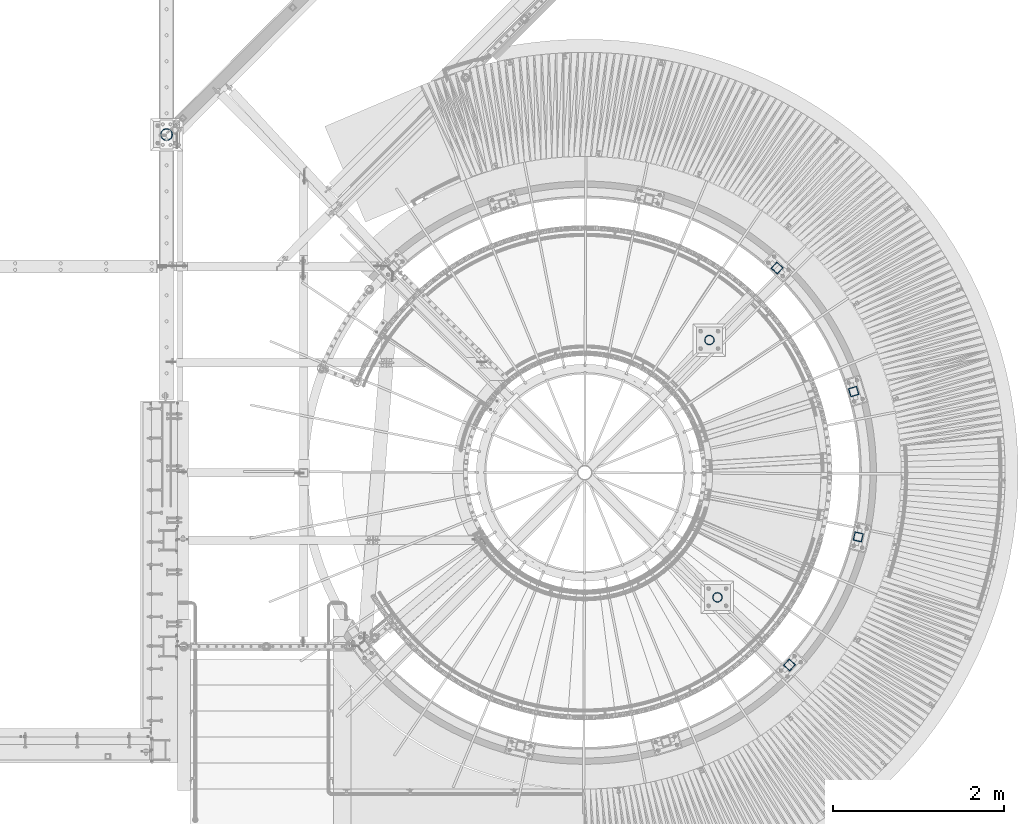
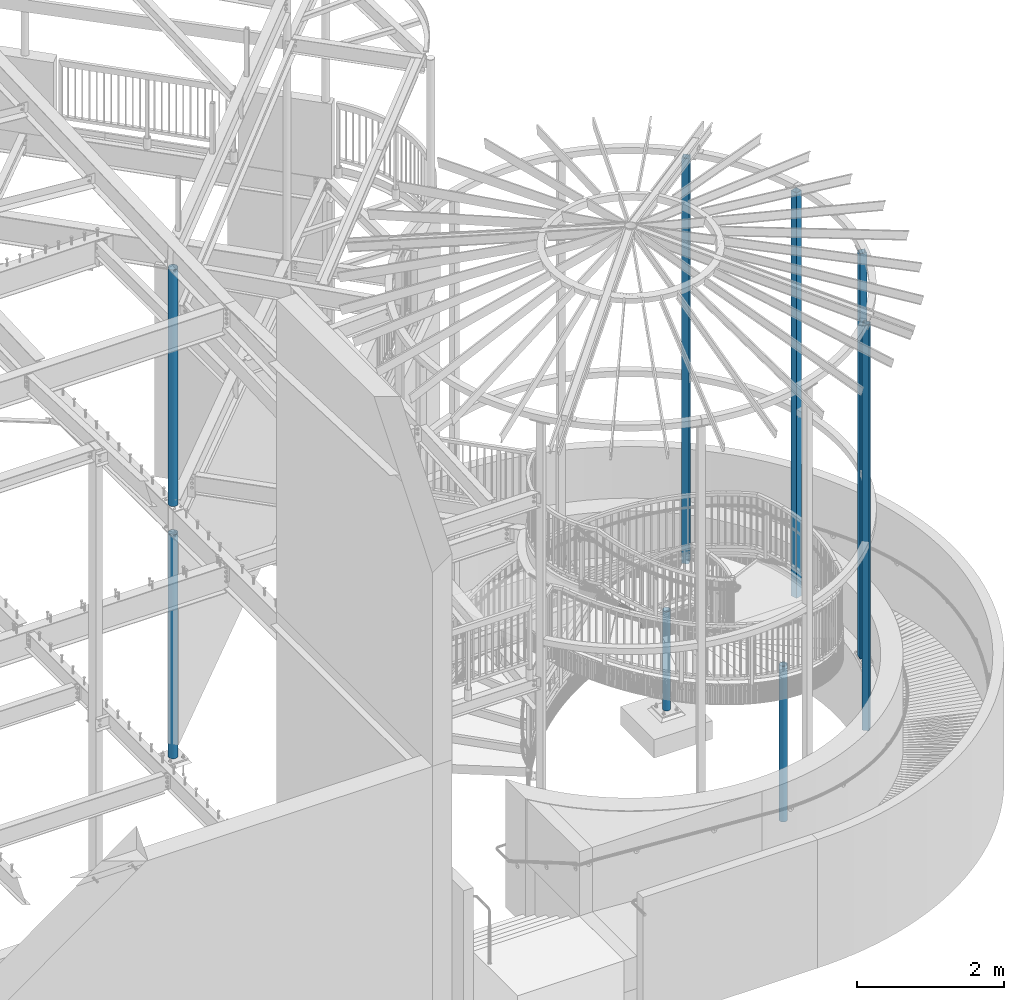
# One storey, part 135 of 975: 8 columns.
"""IFC2X3 building model written with IfcOpenShell, lengths in millimetres."""

from ifc_helpers import new_model, si_unit, frame, origin_with_axes, place, context, subcontext, project, spatial, faceted_brep, material, type_object, element, save


model = new_model("IFC2X3")

# Units and contexts
model_context = context("Model", 3, precision=1e-05, world=origin_with_axes())
body_context = subcontext(model_context, "Body", "Model", "MODEL_VIEW")
ifc_project = project(units=[si_unit("LENGTHUNIT", "METRE", prefix="MILLI"), si_unit("AREAUNIT", "SQUARE_METRE"), si_unit("VOLUMEUNIT", "CUBIC_METRE"), si_unit("MASSUNIT", "GRAM", prefix="KILO"), si_unit("TIMEUNIT", "SECOND"), si_unit("PLANEANGLEUNIT", "RADIAN"), si_unit("SOLIDANGLEUNIT", "STERADIAN"), si_unit("THERMODYNAMICTEMPERATUREUNIT", "DEGREE_CELSIUS"), si_unit("LUMINOUSINTENSITYUNIT", "LUMEN")], contexts=[model_context])

# Site, building, storey
site_placement = place(None, origin_with_axes())
site = spatial("IfcSite", under=ifc_project, at=site_placement, CompositionType="ELEMENT")
building_placement = place(site_placement, origin_with_axes())
building = spatial("IfcBuilding", under=site, at=building_placement, Name="Undefined", CompositionType="ELEMENT")
storey_placement = place(building_placement, origin_with_axes())
storey = spatial("IfcBuildingStorey", under=building, at=storey_placement, Name="Undefined", CompositionType="ELEMENT", Elevation=0.0)

# Columns
ifc_material_1 = material(Name="STEEL/A53")
column_type_1 = type_object("IfcColumnType", Name="PIPE5STD", PredefinedType="NOTDEFINED")
column_1_placement = place(storey_placement, frame((29832.3, 7367.5875, 3932.33453205406), z_axis=(0.0, 1.0, 0.0), x_axis=(0.0, 0.0, 1.0)))
element("IfcColumn", 1, at=column_1_placement, inside=storey, type_object=column_type_1, material=ifc_material_1, Name="COLUMN", ObjectType="PIPE5STD", context=body_context, shape_type="Brep", body=[
    faceted_brep([(17.3654679459351, -64.0587999999989, 0.0), (17.3654679459351, -60.9235391660477, 19.795257839266), (3947.22750081436, -60.9235391660477, 19.795257839266), (3946.40423276926, -64.0587999999989, 0.0), (17.3654679459351, -51.8246578392645, 37.6528179195529), (3947.97018164717, -51.8246578392645, 37.6528179195529), (17.3654679459351, -37.652817919552, 51.8246578392655), (3948.5595764932, -37.652817919552, 51.8246578392655), (17.3654679459351, -19.7952578392651, 60.9235391660477), (3948.93799127836, -19.7952578392651, 60.9235391660477), (17.3654679459351, 0.0, 64.0587999999998), (3949.06838412692, 0.0, 64.0587999999998), (17.3654679459351, 19.7952578392651, 60.9235391660477), (3948.93799127836, 19.7952578392651, 60.9235391660477), (17.3654679459351, 37.652817919552, 51.8246578392655), (3948.5595764932, 37.652817919552, 51.8246578392655), (17.3654679459351, 51.8246578392645, 37.6528179195529), (3947.97018164717, 51.8246578392645, 37.6528179195529), (17.3654679459351, 60.9235391660477, 19.795257839266), (3947.22750081436, 60.9235391660477, 19.795257839266), (17.3654679459351, 64.0587999999989, 0.0), (3946.40423276926, 64.0587999999989, 0.0), (17.3654679459351, 60.9235391660477, -19.795257839266), (3945.58096472415, 60.9235391660477, -19.795257839266), (17.3654679459351, 51.8246578392645, -37.6528179195529), (3944.83828389135, 51.8246578392645, -37.6528179195529), (17.3654679459351, 37.652817919552, -51.8246578392655), (3944.24888904532, 37.652817919552, -51.8246578392655), (17.3654679459351, 19.7952578392651, -60.9235391660477), (3943.87047426016, 19.7952578392651, -60.9235391660477), (17.3654679459351, 0.0, -64.0587999999998), (3943.74008141159, 0.0, -64.0587999999998), (17.3654679459351, -19.7952578392651, -60.9235391660477), (3943.87047426016, -19.7952578392651, -60.9235391660477), (17.3654679459351, -37.652817919552, -51.8246578392655), (3944.24888904532, -37.652817919552, -51.8246578392655), (17.3654679459351, -51.8246578392645, -37.6528179195529), (3944.83828389135, -51.8246578392645, -37.6528179195529), (17.3654679459351, -60.9235391660477, -19.795257839266), (3945.58096472415, -60.9235391660477, -19.795257839266), (17.3654679459351, -70.612000000001, 0.0), (17.3654679459351, -67.1560027286323, -21.8203080068042), (3945.496744599, -67.1560027286323, -21.8203080068042), (3946.40423276926, -70.612000000001, 0.0), (17.3654679459351, -57.126308006802, -41.5046922348765), (3944.67808769369, -57.126308006802, -41.5046922348765), (17.3654679459351, -41.5046922348774, -57.1263080068038), (3944.02839789513, -41.5046922348774, -57.1263080068038), (17.3654679459351, -21.8203080068051, -67.1560027286332), (3943.61127136747, -21.8203080068051, -67.1560027286332), (17.3654679459351, 0.0, -70.6120000000001), (3943.46753936152, 0.0, -70.6120000000001), (17.3654679459351, 21.8203080068051, -67.1560027286332), (3943.61127136747, 21.8203080068051, -67.1560027286332), (17.3654679459351, 41.5046922348774, -57.1263080068038), (3944.02839789513, 41.5046922348774, -57.1263080068038), (17.3654679459351, 57.126308006802, -41.5046922348765), (3944.67808769369, 57.126308006802, -41.5046922348765), (17.3654679459351, 67.1560027286323, -21.8203080068042), (3945.496744599, 67.1560027286323, -21.8203080068042), (17.3654679459351, 70.612000000001, 0.0), (3946.40423276926, 70.612000000001, 0.0), (17.3654679459351, 67.1560027286323, 21.8203080068042), (3947.31172093952, 67.1560027286323, 21.8203080068042), (17.3654679459351, 57.126308006802, 41.5046922348765), (3948.13037784483, 57.126308006802, 41.5046922348765), (17.3654679459351, 41.5046922348774, 57.1263080068038), (3948.78006764339, 41.5046922348774, 57.1263080068038), (17.3654679459351, 21.8203080068051, 67.1560027286332), (3949.19719417105, 21.8203080068051, 67.1560027286332), (17.3654679459351, 0.0, 70.6120000000001), (3949.34092617699, 0.0, 70.6120000000001), (17.3654679459351, -21.8203080068051, 67.1560027286332), (3949.19719417105, -21.8203080068051, 67.1560027286332), (17.3654679459351, -41.5046922348774, 57.1263080068038), (3948.78006764339, -41.5046922348774, 57.1263080068038), (17.3654679459351, -57.126308006802, 41.5046922348765), (3948.13037784483, -57.126308006802, 41.5046922348765), (17.3654679459351, -67.1560027286323, 21.8203080068042), (3947.31172093952, -67.1560027286323, 21.8203080068042)], [[[0, 1, 2, 3]], [[1, 4, 5, 2]], [[4, 6, 7, 5]], [[6, 8, 9, 7]], [[8, 10, 11, 9]], [[10, 12, 13, 11]], [[12, 14, 15, 13]], [[14, 16, 17, 15]], [[16, 18, 19, 17]], [[18, 20, 21, 19]], [[20, 22, 23, 21]], [[22, 24, 25, 23]], [[24, 26, 27, 25]], [[26, 28, 29, 27]], [[28, 30, 31, 29]], [[30, 32, 33, 31]], [[32, 34, 35, 33]], [[34, 36, 37, 35]], [[36, 38, 39, 37]], [[38, 0, 3, 39]], [[40, 41, 42, 43]], [[41, 44, 45, 42]], [[44, 46, 47, 45]], [[46, 48, 49, 47]], [[48, 50, 51, 49]], [[50, 52, 53, 51]], [[52, 54, 55, 53]], [[54, 56, 57, 55]], [[56, 58, 59, 57]], [[58, 60, 61, 59]], [[60, 62, 63, 61]], [[62, 64, 65, 63]], [[64, 66, 67, 65]], [[66, 68, 69, 67]], [[68, 70, 71, 69]], [[70, 72, 73, 71]], [[72, 74, 75, 73]], [[74, 76, 77, 75]], [[76, 78, 79, 77]], [[78, 40, 43, 79]], [[45, 47, 49, 51, 53, 55, 57, 59, 61, 63, 65, 67, 69, 71, 73, 75, 77, 79, 43, 42], [5, 7, 9, 11, 13, 15, 17, 19, 21, 23, 25, 27, 29, 31, 33, 35, 37, 39, 3, 2]], [[78, 76, 74, 72, 70, 68, 66, 64, 62, 60, 58, 56, 54, 52, 50, 48, 46, 44, 41, 40], [38, 36, 34, 32, 30, 28, 26, 24, 22, 20, 18, 16, 14, 12, 10, 8, 6, 4, 1, 0]]]),
])
column_2_placement = place(storey_placement, frame((29832.3, 7367.5875, -266.7), z_axis=(0.0, 1.0, 0.0), x_axis=(0.0, 0.0, 1.0)))
element("IfcColumn", 2, at=column_2_placement, inside=storey, type_object=column_type_1, material=ifc_material_1, Name="COLUMN", ObjectType="PIPE5STD", context=body_context, shape_type="Brep", body=[
    faceted_brep([(25.3999999999999, -64.0587999999989, 0.0), (25.3999999999999, -60.9235391660477, 19.795257839266), (3740.15, -60.9235391660477, 19.795257839266), (3740.15, -64.0587999999989, 0.0), (25.3999999999999, -51.8246578392645, 37.6528179195529), (3740.15, -51.8246578392645, 37.6528179195529), (25.3999999999999, -37.652817919552, 51.8246578392655), (3740.15, -37.652817919552, 51.8246578392655), (25.3999999999999, -19.7952578392651, 60.9235391660477), (3740.15, -19.7952578392651, 60.9235391660477), (25.3999999999999, 0.0, 64.0587999999998), (3740.15, 0.0, 64.0587999999998), (25.3999999999999, 19.7952578392651, 60.9235391660477), (3740.15, 19.7952578392651, 60.9235391660477), (25.3999999999999, 37.652817919552, 51.8246578392655), (3740.15, 37.652817919552, 51.8246578392655), (25.3999999999999, 51.8246578392645, 37.6528179195529), (3740.15, 51.8246578392645, 37.6528179195529), (25.3999999999999, 60.9235391660477, 19.795257839266), (3740.15, 60.9235391660477, 19.795257839266), (25.3999999999999, 64.0587999999989, 0.0), (3740.15, 64.0587999999989, 0.0), (25.3999999999999, 60.9235391660477, -19.795257839266), (3740.15, 60.9235391660477, -19.795257839266), (25.3999999999999, 51.8246578392645, -37.6528179195529), (3740.15, 51.8246578392645, -37.6528179195529), (25.3999999999999, 37.652817919552, -51.8246578392655), (3740.15, 37.652817919552, -51.8246578392655), (25.3999999999999, 19.7952578392651, -60.9235391660477), (3740.15, 19.7952578392651, -60.9235391660477), (25.3999999999999, 0.0, -64.0587999999998), (3740.15, 0.0, -64.0587999999998), (25.3999999999999, -19.7952578392651, -60.9235391660477), (3740.15, -19.7952578392651, -60.9235391660477), (25.3999999999999, -37.652817919552, -51.8246578392655), (3740.15, -37.652817919552, -51.8246578392655), (25.3999999999999, -51.8246578392645, -37.6528179195529), (3740.15, -51.8246578392645, -37.6528179195529), (25.3999999999999, -60.9235391660477, -19.795257839266), (3740.15, -60.9235391660477, -19.795257839266), (25.3999999999999, -70.612000000001, 0.0), (25.3999999999999, -67.1560027286323, -21.8203080068042), (3740.15, -67.1560027286323, -21.8203080068042), (3740.15, -70.612000000001, 0.0), (25.3999999999999, -57.126308006802, -41.5046922348765), (3740.15, -57.126308006802, -41.5046922348765), (25.3999999999999, -41.5046922348774, -57.1263080068038), (3740.15, -41.5046922348774, -57.1263080068038), (25.3999999999999, -21.8203080068051, -67.1560027286332), (3740.15, -21.8203080068051, -67.1560027286332), (25.3999999999999, 0.0, -70.6120000000001), (3740.15, 0.0, -70.6120000000001), (25.3999999999999, 21.8203080068051, -67.1560027286332), (3740.15, 21.8203080068051, -67.1560027286332), (25.3999999999999, 41.5046922348774, -57.1263080068038), (3740.15, 41.5046922348774, -57.1263080068038), (25.3999999999999, 57.126308006802, -41.5046922348765), (3740.15, 57.126308006802, -41.5046922348765), (25.3999999999999, 67.1560027286323, -21.8203080068042), (3740.15, 67.1560027286323, -21.8203080068042), (25.3999999999999, 70.612000000001, 0.0), (3740.15, 70.612000000001, 0.0), (25.3999999999999, 67.1560027286323, 21.8203080068042), (3740.15, 67.1560027286323, 21.8203080068042), (25.3999999999999, 57.126308006802, 41.5046922348765), (3740.15, 57.126308006802, 41.5046922348765), (25.3999999999999, 41.5046922348774, 57.1263080068038), (3740.15, 41.5046922348774, 57.1263080068038), (25.3999999999999, 21.8203080068051, 67.1560027286332), (3740.15, 21.8203080068051, 67.1560027286332), (25.3999999999999, 0.0, 70.6120000000001), (3740.15, 0.0, 70.6120000000001), (25.3999999999999, -21.8203080068051, 67.1560027286332), (3740.15, -21.8203080068051, 67.1560027286332), (25.3999999999999, -41.5046922348774, 57.1263080068038), (3740.15, -41.5046922348774, 57.1263080068038), (25.3999999999999, -57.126308006802, 41.5046922348765), (3740.15, -57.126308006802, 41.5046922348765), (25.3999999999999, -67.1560027286323, 21.8203080068042), (3740.15, -67.1560027286323, 21.8203080068042)], [[[0, 1, 2, 3]], [[1, 4, 5, 2]], [[4, 6, 7, 5]], [[6, 8, 9, 7]], [[8, 10, 11, 9]], [[10, 12, 13, 11]], [[12, 14, 15, 13]], [[14, 16, 17, 15]], [[16, 18, 19, 17]], [[18, 20, 21, 19]], [[20, 22, 23, 21]], [[22, 24, 25, 23]], [[24, 26, 27, 25]], [[26, 28, 29, 27]], [[28, 30, 31, 29]], [[30, 32, 33, 31]], [[32, 34, 35, 33]], [[34, 36, 37, 35]], [[36, 38, 39, 37]], [[38, 0, 3, 39]], [[40, 41, 42, 43]], [[41, 44, 45, 42]], [[44, 46, 47, 45]], [[46, 48, 49, 47]], [[48, 50, 51, 49]], [[50, 52, 53, 51]], [[52, 54, 55, 53]], [[54, 56, 57, 55]], [[56, 58, 59, 57]], [[58, 60, 61, 59]], [[60, 62, 63, 61]], [[62, 64, 65, 63]], [[64, 66, 67, 65]], [[66, 68, 69, 67]], [[68, 70, 71, 69]], [[70, 72, 73, 71]], [[72, 74, 75, 73]], [[74, 76, 77, 75]], [[76, 78, 79, 77]], [[78, 40, 43, 79]], [[45, 47, 49, 51, 53, 55, 57, 59, 61, 63, 65, 67, 69, 71, 73, 75, 77, 79, 43, 42], [5, 7, 9, 11, 13, 15, 17, 19, 21, 23, 25, 27, 29, 31, 33, 35, 37, 39, 3, 2]], [[78, 76, 74, 72, 70, 68, 66, 64, 62, 60, 58, 56, 54, 52, 50, 48, 46, 44, 41, 40], [38, 36, 34, 32, 30, 28, 26, 24, 22, 20, 18, 16, 14, 12, 10, 8, 6, 4, 1, 0]]]),
])
ifc_material_2 = material()
column_type_2 = type_object("IfcColumnType", Name="HSS4X4X1/4", PredefinedType="NOTDEFINED")
for number, where, z_axis, x_axis, name in (
    (3, (37134.1754352767, 1149.37181537194, 1409.7), (-0.684674324933948, -0.728849139929686, 0.0), (0.0, 0.0, 1.0), "COLUMN"),
    (4, (37939.813454417, 2651.21427254825, 1409.7), (-0.228520788077446, -0.973539033329667, 0.0), (0.0, 0.0, 1.0), "COLUMN"),
    (5, (37886.5912561751, 4354.67625471515, 1409.7), (0.288864709123643, -0.957369928409553, 0.0), (0.0, 0.0, 1.0), "COLUMN"),
    (6, (36988.7269838111, 5803.27415698072, 1409.7), (0.73176109614993, -0.68156122113971, 0.0), (0.0, 0.0, 1.0), "COLUMN"),
):
    element("IfcColumn", number, at=place(storey_placement, frame(where, z_axis=z_axis, x_axis=x_axis)), inside=storey, type_object=column_type_2, material=ifc_material_2, Name=name, ObjectType="HSS4X4X1/4", context=body_context, shape_type="Brep", body=[
        faceted_brep([(19.0499999999988, 44.4499999999998, -44.4500000000007), (19.0499999999988, -44.4499999999998, -44.4500000000007), (6753.225, -44.4499999999571, -44.4499999999389), (6753.225, 44.4500000000589, -44.4499999999462), (19.0499999999988, -44.4499999999998, 44.4500000000007), (6753.225, -44.4500000000626, 44.4499999999607), (19.0499999999988, 44.4499999999998, 44.4500000000007), (6753.225, 44.4499999999571, 44.4499999999498), (19.0499999999988, 50.8000000000002, -50.7999999999993), (19.0499999999988, 50.8000000000002, 50.7999999999993), (6753.225, 50.7999999999483, 50.7999999999447), (6753.225, 50.8000000000648, -50.7999999999447), (19.0499999999988, -50.8000000000002, 50.7999999999993), (6753.225, -50.800000000072, 50.799999999952), (19.0499999999988, -50.8000000000002, -50.7999999999993), (6753.225, -50.7999999999556, -50.7999999999302)], [[[0, 1, 2, 3]], [[1, 4, 5, 2]], [[4, 6, 7, 5]], [[6, 0, 3, 7]], [[8, 9, 10, 11]], [[9, 12, 13, 10]], [[12, 14, 15, 13]], [[14, 8, 11, 15]], [[13, 15, 11, 10], [5, 7, 3, 2]], [[14, 12, 9, 8], [6, 4, 1, 0]]]),
    ])
column_type_3 = type_object("IfcColumnType", Name="PIPE4STD", PredefinedType="NOTDEFINED")
column_3_placement = place(storey_placement, frame((36195.3595913399, 4958.69262568473, -241.3), z_axis=(0.0, 1.0, 0.0), x_axis=(0.0, 0.0, 1.0)))
element("IfcColumn", 7, at=column_3_placement, inside=storey, type_object=column_type_3, material=ifc_material_1, Name="COLUMN", ObjectType="PIPE4STD", context=body_context, shape_type="Brep", body=[
    faceted_brep([(19.0500000000025, -51.1301999999996, 0.0), (19.0500000000025, -48.6277098894743, 15.8001007257917), (1666.875, -48.6277098894716, 15.8001007257899), (1666.875, -51.1301999999996, 0.0), (19.0500000000025, -41.3652007257897, 30.0535775067656), (1666.875, -41.3652007257915, 30.0535775067647), (19.0500000000025, -30.0535775067647, 41.3652007257915), (1666.875, -30.0535775067619, 41.3652007257897), (19.0500000000025, -15.8001007257899, 48.6277098894752), (1666.875, -15.8001007257917, 48.6277098894743), (19.0500000000025, 0.0, 51.1301999999996), (1666.875, 0.0, 51.1301999999996), (19.0500000000025, 15.8001007257899, 48.6277098894752), (1666.875, 15.8001007257917, 48.6277098894743), (19.0500000000025, 30.0535775067647, 41.3652007257915), (1666.875, 30.0535775067619, 41.3652007257897), (19.0500000000025, 41.3652007257897, 30.0535775067656), (1666.875, 41.3652007257915, 30.0535775067647), (19.0500000000025, 48.6277098894743, 15.8001007257917), (1666.875, 48.6277098894716, 15.8001007257899), (19.0500000000025, 51.1301999999996, 0.0), (1666.875, 51.1301999999996, 0.0), (19.0500000000025, 48.6277098894743, -15.8001007257917), (1666.875, 48.6277098894716, -15.8001007257899), (19.0500000000025, 41.3652007257897, -30.0535775067656), (1666.875, 41.3652007257915, -30.0535775067647), (19.0500000000025, 30.0535775067647, -41.3652007257915), (1666.875, 30.0535775067619, -41.3652007257897), (19.0500000000025, 15.8001007257899, -48.6277098894752), (1666.875, 15.8001007257917, -48.6277098894743), (19.0500000000025, 0.0, -51.1301999999996), (1666.875, 0.0, -51.1301999999996), (19.0500000000025, -15.8001007257899, -48.6277098894752), (1666.875, -15.8001007257917, -48.6277098894743), (19.0500000000025, -30.0535775067647, -41.3652007257915), (1666.875, -30.0535775067619, -41.3652007257897), (19.0500000000025, -41.3652007257897, -30.0535775067656), (1666.875, -41.3652007257915, -30.0535775067647), (19.0500000000025, -48.6277098894743, -15.8001007257917), (1666.875, -48.6277098894716, -15.8001007257899), (19.0500000000025, -57.1499999999996, 0.0), (19.0500000000025, -54.3528799062678, -17.6603212285299), (1666.875, -54.3528799062697, -17.6603212285281), (1666.875, -57.1500000000015, 0.0), (19.0500000000025, -46.2353212285279, -33.5919271685161), (1666.875, -46.2353212285307, -33.5919271685152), (19.0500000000025, -33.5919271685152, -46.235321228527), (1666.875, -33.5919271685125, -46.2353212285279), (19.0500000000025, -17.6603212285281, -54.3528799062697), (1666.875, -17.6603212285263, -54.3528799062678), (19.0500000000025, 0.0, -57.1500000000015), (1666.875, 0.0, -57.1499999999996), (19.0500000000025, 17.6603212285281, -54.3528799062697), (1666.875, 17.6603212285263, -54.3528799062678), (19.0500000000025, 33.5919271685152, -46.235321228527), (1666.875, 33.5919271685125, -46.2353212285279), (19.0500000000025, 46.2353212285279, -33.5919271685161), (1666.875, 46.2353212285307, -33.5919271685152), (19.0500000000025, 54.3528799062678, -17.6603212285299), (1666.875, 54.3528799062697, -17.6603212285281), (19.0500000000025, 57.1499999999996, 0.0), (1666.875, 57.1500000000015, 0.0), (19.0500000000025, 54.3528799062678, 17.6603212285299), (1666.875, 54.3528799062697, 17.6603212285281), (19.0500000000025, 46.2353212285279, 33.5919271685161), (1666.875, 46.2353212285307, 33.5919271685152), (19.0500000000025, 33.5919271685152, 46.235321228527), (1666.875, 33.5919271685125, 46.2353212285279), (19.0500000000025, 17.6603212285281, 54.3528799062697), (1666.875, 17.6603212285263, 54.3528799062678), (19.0500000000025, 0.0, 57.1500000000015), (1666.875, 0.0, 57.1499999999996), (19.0500000000025, -17.6603212285281, 54.3528799062697), (1666.875, -17.6603212285263, 54.3528799062678), (19.0500000000025, -33.5919271685152, 46.235321228527), (1666.875, -33.5919271685125, 46.2353212285279), (19.0500000000025, -46.2353212285279, 33.5919271685161), (1666.875, -46.2353212285307, 33.5919271685152), (19.0500000000025, -54.3528799062678, 17.6603212285299), (1666.875, -54.3528799062697, 17.6603212285281)], [[[0, 1, 2, 3]], [[1, 4, 5, 2]], [[4, 6, 7, 5]], [[6, 8, 9, 7]], [[8, 10, 11, 9]], [[10, 12, 13, 11]], [[12, 14, 15, 13]], [[14, 16, 17, 15]], [[16, 18, 19, 17]], [[18, 20, 21, 19]], [[20, 22, 23, 21]], [[22, 24, 25, 23]], [[24, 26, 27, 25]], [[26, 28, 29, 27]], [[28, 30, 31, 29]], [[30, 32, 33, 31]], [[32, 34, 35, 33]], [[34, 36, 37, 35]], [[36, 38, 39, 37]], [[38, 0, 3, 39]], [[40, 41, 42, 43]], [[41, 44, 45, 42]], [[44, 46, 47, 45]], [[46, 48, 49, 47]], [[48, 50, 51, 49]], [[50, 52, 53, 51]], [[52, 54, 55, 53]], [[54, 56, 57, 55]], [[56, 58, 59, 57]], [[58, 60, 61, 59]], [[60, 62, 63, 61]], [[62, 64, 65, 63]], [[64, 66, 67, 65]], [[66, 68, 69, 67]], [[68, 70, 71, 69]], [[70, 72, 73, 71]], [[72, 74, 75, 73]], [[74, 76, 77, 75]], [[76, 78, 79, 77]], [[78, 40, 43, 79]], [[45, 47, 49, 51, 53, 55, 57, 59, 61, 63, 65, 67, 69, 71, 73, 75, 77, 79, 43, 42], [5, 7, 9, 11, 13, 15, 17, 19, 21, 23, 25, 27, 29, 31, 33, 35, 37, 39, 3, 2]], [[78, 76, 74, 72, 70, 68, 66, 64, 62, 60, 58, 56, 54, 52, 50, 48, 46, 44, 41, 40], [38, 36, 34, 32, 30, 28, 26, 24, 22, 20, 18, 16, 14, 12, 10, 8, 6, 4, 1, 0]]]),
])
column_4_placement = place(storey_placement, frame((36289.6174033398, 1942.7404086606, -292.1), z_axis=(0.0, 1.0, 0.0), x_axis=(0.0, 0.0, 1.0)))
element("IfcColumn", 8, at=column_4_placement, inside=storey, type_object=column_type_3, material=ifc_material_1, Name="COLUMN", ObjectType="PIPE4STD", context=body_context, shape_type="Brep", body=[
    faceted_brep([(19.0500000000025, -51.1301999999996, 0.0), (19.0500000000025, -48.6277098894743, 15.8001007257917), (2606.90794886957, -48.6277098894716, 15.8001007257899), (2606.90794886957, -51.1301999999996, 0.0), (19.0500000000025, -41.3652007257897, 30.0535775067656), (2606.90794886957, -41.3652007257915, 30.0535775067647), (19.0500000000025, -30.0535775067647, 41.3652007257915), (2606.90794886957, -30.0535775067619, 41.3652007257899), (19.0500000000025, -15.8001007257899, 48.6277098894752), (2606.90794886957, -15.8001007257917, 48.6277098894745), (19.0500000000025, 0.0, 51.1301999999996), (2606.90794886957, 0.0, 51.1302000000001), (19.0500000000025, 15.8001007257899, 48.6277098894752), (2606.90794886957, 15.8001007257917, 48.6277098894745), (19.0500000000025, 30.0535775067647, 41.3652007257915), (2606.90794886957, 30.0535775067619, 41.3652007257899), (19.0500000000025, 41.3652007257897, 30.0535775067656), (2606.90794886957, 41.3652007257915, 30.0535775067647), (19.0500000000025, 48.6277098894743, 15.8001007257917), (2606.90794886957, 48.6277098894716, 15.8001007257899), (19.0500000000025, 51.1301999999996, 0.0), (2606.90794886957, 51.1301999999996, 0.0), (19.0500000000025, 48.6277098894743, -15.8001007257917), (2606.90794886957, 48.6277098894716, -15.8001007257899), (19.0500000000025, 41.3652007257897, -30.0535775067656), (2606.90794886957, 41.3652007257915, -30.0535775067647), (19.0500000000025, 30.0535775067647, -41.3652007257915), (2606.90794886957, 30.0535775067619, -41.3652007257899), (19.0500000000025, 15.8001007257899, -48.6277098894752), (2606.90794886957, 15.8001007257917, -48.6277098894745), (19.0500000000025, 0.0, -51.1301999999996), (2606.90794886957, 0.0, -51.1302000000001), (19.0500000000025, -15.8001007257899, -48.6277098894752), (2606.90794886957, -15.8001007257917, -48.6277098894745), (19.0500000000025, -30.0535775067647, -41.3652007257915), (2606.90794886957, -30.0535775067619, -41.3652007257899), (19.0500000000025, -41.3652007257897, -30.0535775067656), (2606.90794886957, -41.3652007257915, -30.0535775067647), (19.0500000000025, -48.6277098894743, -15.8001007257917), (2606.90794886957, -48.6277098894716, -15.8001007257899), (19.0500000000025, -57.1499999999996, 0.0), (19.0500000000025, -54.3528799062678, -17.6603212285299), (2606.90794886957, -54.3528799062697, -17.6603212285283), (2606.90794886957, -57.1500000000015, 0.0), (19.0500000000025, -46.2353212285279, -33.5919271685161), (2606.90794886957, -46.2353212285307, -33.5919271685148), (19.0500000000025, -33.5919271685152, -46.235321228527), (2606.90794886957, -33.5919271685125, -46.2353212285282), (19.0500000000025, -17.6603212285281, -54.3528799062697), (2606.90794886957, -17.6603212285263, -54.3528799062681), (19.0500000000025, 0.0, -57.1500000000015), (2606.90794886957, 0.0, -57.1500000000001), (19.0500000000025, 17.6603212285281, -54.3528799062697), (2606.90794886957, 17.6603212285263, -54.3528799062681), (19.0500000000025, 33.5919271685152, -46.235321228527), (2606.90794886957, 33.5919271685125, -46.2353212285282), (19.0500000000025, 46.2353212285279, -33.5919271685161), (2606.90794886957, 46.2353212285307, -33.5919271685148), (19.0500000000025, 54.3528799062678, -17.6603212285299), (2606.90794886957, 54.3528799062697, -17.6603212285283), (19.0500000000025, 57.1499999999996, 0.0), (2606.90794886957, 57.1500000000015, 0.0), (19.0500000000025, 54.3528799062678, 17.6603212285299), (2606.90794886957, 54.3528799062697, 17.6603212285283), (19.0500000000025, 46.2353212285279, 33.5919271685161), (2606.90794886957, 46.2353212285307, 33.5919271685148), (19.0500000000025, 33.5919271685152, 46.235321228527), (2606.90794886957, 33.5919271685125, 46.2353212285282), (19.0500000000025, 17.6603212285281, 54.3528799062697), (2606.90794886957, 17.6603212285263, 54.3528799062681), (19.0500000000025, 0.0, 57.1500000000015), (2606.90794886957, 0.0, 57.1500000000001), (19.0500000000025, -17.6603212285281, 54.3528799062697), (2606.90794886957, -17.6603212285263, 54.3528799062681), (19.0500000000025, -33.5919271685152, 46.235321228527), (2606.90794886957, -33.5919271685125, 46.2353212285282), (19.0500000000025, -46.2353212285279, 33.5919271685161), (2606.90794886957, -46.2353212285307, 33.5919271685148), (19.0500000000025, -54.3528799062678, 17.6603212285299), (2606.90794886957, -54.3528799062697, 17.6603212285283)], [[[0, 1, 2, 3]], [[1, 4, 5, 2]], [[4, 6, 7, 5]], [[6, 8, 9, 7]], [[8, 10, 11, 9]], [[10, 12, 13, 11]], [[12, 14, 15, 13]], [[14, 16, 17, 15]], [[16, 18, 19, 17]], [[18, 20, 21, 19]], [[20, 22, 23, 21]], [[22, 24, 25, 23]], [[24, 26, 27, 25]], [[26, 28, 29, 27]], [[28, 30, 31, 29]], [[30, 32, 33, 31]], [[32, 34, 35, 33]], [[34, 36, 37, 35]], [[36, 38, 39, 37]], [[38, 0, 3, 39]], [[40, 41, 42, 43]], [[41, 44, 45, 42]], [[44, 46, 47, 45]], [[46, 48, 49, 47]], [[48, 50, 51, 49]], [[50, 52, 53, 51]], [[52, 54, 55, 53]], [[54, 56, 57, 55]], [[56, 58, 59, 57]], [[58, 60, 61, 59]], [[60, 62, 63, 61]], [[62, 64, 65, 63]], [[64, 66, 67, 65]], [[66, 68, 69, 67]], [[68, 70, 71, 69]], [[70, 72, 73, 71]], [[72, 74, 75, 73]], [[74, 76, 77, 75]], [[76, 78, 79, 77]], [[78, 40, 43, 79]], [[45, 47, 49, 51, 53, 55, 57, 59, 61, 63, 65, 67, 69, 71, 73, 75, 77, 79, 43, 42], [5, 7, 9, 11, 13, 15, 17, 19, 21, 23, 25, 27, 29, 31, 33, 35, 37, 39, 3, 2]], [[78, 76, 74, 72, 70, 68, 66, 64, 62, 60, 58, 56, 54, 52, 50, 48, 46, 44, 41, 40], [38, 36, 34, 32, 30, 28, 26, 24, 22, 20, 18, 16, 14, 12, 10, 8, 6, 4, 1, 0]]]),
])

save(model, "model.ifc")
